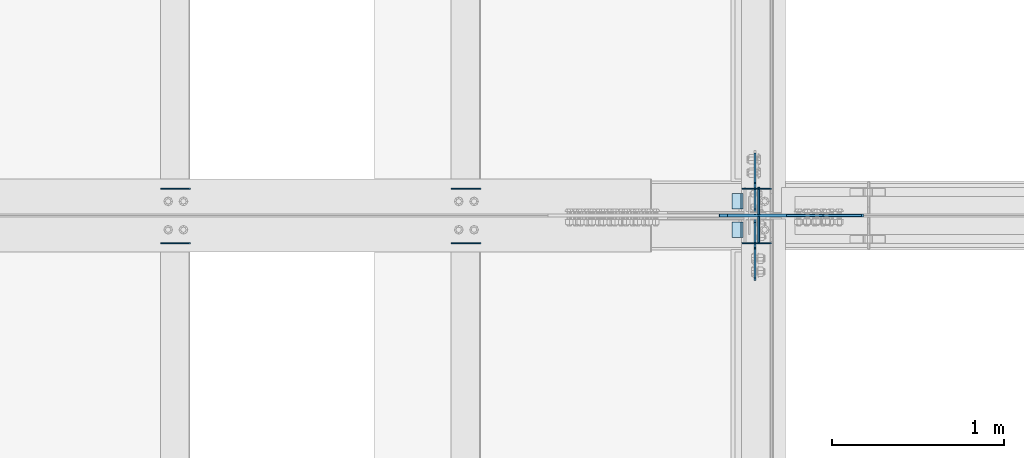
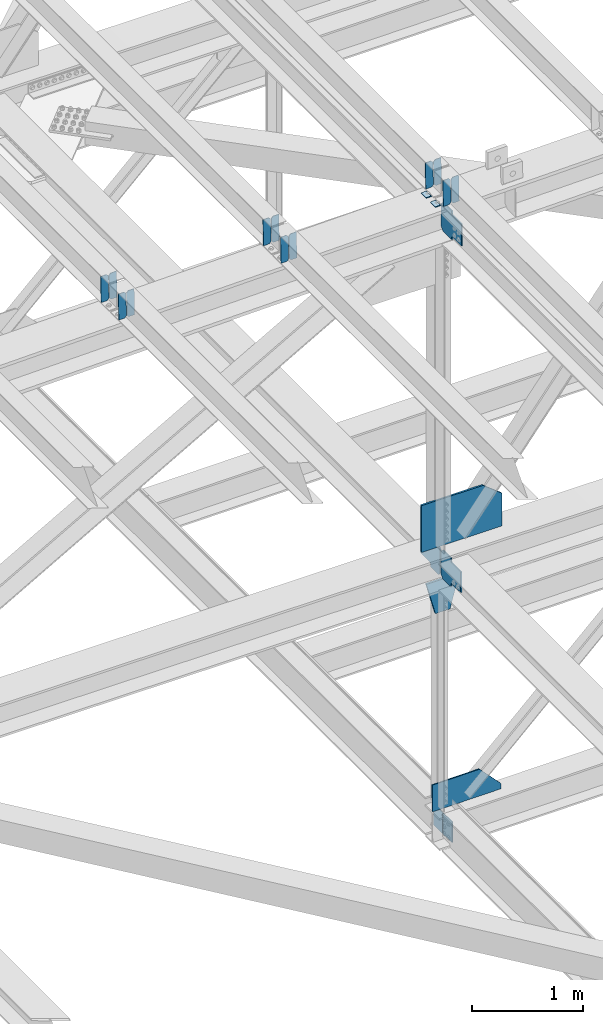
# One storey, part 3315 of 3843: 22 plates, 9 elements without a shape of their own.
"""IFC2X3 building model written with IfcOpenShell, lengths in millimetres."""

import ifcopenshell
import ifcopenshell.guid

model = None  # the IFC model being written
_history = None  # IfcOwnerHistory: only IFC2X3 demands one
_inside = {}  # id of a spatial element -> (the spatial element, [elements in it])
_under = {}  # id of a project, library or spatial element -> (it, [spatial elements below it])
_declared = {}  # id of a project -> (the project, [libraries it declares])
_typed = {}  # id of a type object -> (the type object, [elements of that type])
_made_of = {}  # id of a material, layer set ... -> (it, [elements and type objects made of it])


def new_model(schema):
    """Start an empty IFC model of exactly this schema.

    Asked for "IFC4X3", IfcOpenShell would pick the latest addendum, in which some entities
    have other attributes; the version numbers below select the first issue.
    IFC2X3 requires an IfcOwnerHistory on every rooted entity: one is made here for all.
    """
    global model, _history
    if schema == "IFC4X3":
        model = ifcopenshell.file(schema_version=(4, 3, 0, 0))
    else:
        model = ifcopenshell.file(schema=schema)
    _inside.clear()
    _under.clear()
    _declared.clear()
    _typed.clear()
    _made_of.clear()
    _history = None
    if model.schema == "IFC2X3":
        org = make("IfcOrganization", Name="unknown")
        user = make(
            "IfcPersonAndOrganization",
            ThePerson=make("IfcPerson", FamilyName="unknown"),
            TheOrganization=org,
        )
        app = make(
            "IfcApplication",
            ApplicationDeveloper=org,
            Version="unknown",
            ApplicationFullName="unknown",
            ApplicationIdentifier="unknown",
        )
        _history = make(
            "IfcOwnerHistory",
            OwningUser=user,
            OwningApplication=app,
            ChangeAction="ADDED",
            CreationDate=0,
        )
    return model


def make(cls, **values):
    """One entity of the class cls with the attributes given. An attribute that is None is left unset."""
    return model.create_entity(
        cls, **{name: value for name, value in values.items() if value is not None}
    )


def rooted(cls, **values):
    """An entity with a GlobalId (a new one), such as an element, a storey or a relation."""
    return make(cls, GlobalId=ifcopenshell.guid.new(), OwnerHistory=_history, **values)


def si_unit(unit_type, name, prefix=None):
    """IfcSIUnit, for example si_unit("LENGTHUNIT", "METRE", prefix="MILLI")."""
    return make("IfcSIUnit", UnitType=unit_type, Prefix=prefix, Name=name)


def assignment(units):
    """IfcUnitAssignment: the units of a project."""
    return None if units is None else make("IfcUnitAssignment", Units=units)


def point(xyz):
    """IfcCartesianPoint."""
    return None if xyz is None else make("IfcCartesianPoint", Coordinates=xyz)


def direction(xyz):
    """IfcDirection."""
    return None if xyz is None else make("IfcDirection", DirectionRatios=xyz)


def frame(location, z_axis=None, x_axis=None):
    """IfcAxis2Placement3D, a coordinate frame: its origin and axes. An axis left out is left unset."""
    return make(
        "IfcAxis2Placement3D",
        Location=point(location),
        Axis=direction(z_axis),
        RefDirection=direction(x_axis),
    )


def origin_with_axes():
    """The frame at (0, 0, 0) with the z axis (0, 0, 1) and the x axis (1, 0, 0) written out."""
    return frame((0.0, 0.0, 0.0), z_axis=(0.0, 0.0, 1.0), x_axis=(1.0, 0.0, 0.0))


def place(relative_to, where):
    """IfcLocalPlacement: puts the frame where relative to a parent placement (None: the world)."""
    return make(
        "IfcLocalPlacement", PlacementRelTo=relative_to, RelativePlacement=where
    )


def context(
    kind, dimensions, precision=None, world=None, true_north=None, identifier=None
):
    """IfcGeometricRepresentationContext, for example the 3D "Model" context."""
    return make(
        "IfcGeometricRepresentationContext",
        ContextIdentifier=identifier,
        ContextType=kind,
        CoordinateSpaceDimension=dimensions,
        Precision=precision,
        WorldCoordinateSystem=world,
        TrueNorth=true_north,
    )


def subcontext(parent, identifier, kind, view, scale=None):
    """IfcGeometricRepresentationSubContext, for example "Body" below "Model"."""
    return make(
        "IfcGeometricRepresentationSubContext",
        ContextIdentifier=identifier,
        ContextType=kind,
        ParentContext=parent,
        TargetScale=scale,
        TargetView=view,
    )


def project(units=None, contexts=None):
    """IfcProject with its units and contexts."""
    return rooted(
        "IfcProject",
        Name="project",
        RepresentationContexts=contexts,
        UnitsInContext=assignment(units),
    )


def spatial(cls, under=None, at=None, **own):
    """A site, building, storey or space (cls), placed at a placement, below another one or the project."""
    s = rooted(cls, ObjectPlacement=at, **own)
    if under is not None:
        _under.setdefault(under.id(), (under, []))[1].append(s)
    return s


def faces_of(points, faces, orient=None, outer=None):
    """IfcFace entities. A face is a list of loops; a loop is a list of indices into points, from 0.

    orient and outer hold one flag for each loop. By default every Orientation is true, the
    first loop of a face is its IfcFaceOuterBound and the others are IfcFaceBound.
    """
    made = []
    for i, loops in enumerate(faces):
        bounds = []
        for j, loop in enumerate(loops):
            is_outer = j == 0 if outer is None else outer[i][j]
            bounds.append(
                make(
                    "IfcFaceOuterBound" if is_outer else "IfcFaceBound",
                    Bound=make("IfcPolyLoop", Polygon=[points[k] for k in loop]),
                    Orientation=True if orient is None else orient[i][j],
                )
            )
        made.append(make("IfcFace", Bounds=bounds))
    return made


def faceted_brep(points, faces, orient=None, outer=None, voids=None):
    """IfcFacetedBrep: a solid bounded by flat faces; with voids (closed shells), ...WithVoids."""
    shared = [point(p) for p in points]
    hull = make("IfcClosedShell", CfsFaces=faces_of(shared, faces, orient, outer))
    if voids is None:
        return make("IfcFacetedBrep", Outer=hull)
    return make(
        "IfcFacetedBrepWithVoids",
        Outer=hull,
        Voids=[
            make(cls, CfsFaces=faces_of(shared, fs, o, b)) for cls, fs, o, b in voids
        ],
    )


def shape(context_of_items, identifier, shape_type, items):
    """IfcShapeRepresentation: the items that make up one representation, for example the "Body"."""
    return make(
        "IfcShapeRepresentation",
        ContextOfItems=context_of_items,
        RepresentationIdentifier=identifier,
        RepresentationType=shape_type,
        Items=items,
    )


def material(Name=None, Category=None):
    """IfcMaterial."""
    return make("IfcMaterial", Name=Name, Category=Category)


def made_of(thing, what):
    """Note that an element or type object is made of a material, layer set ...; save() writes the relation."""
    if what is not None:
        _made_of.setdefault(what.id(), (what, []))[1].append(thing)
    return thing


def type_object(cls, material=None, **own):
    """A type object (cls), such as IfcWallType, which elements share."""
    return made_of(rooted(cls, **own), material)


def element(
    cls,
    number,
    at=None,
    inside=None,
    cuts=None,
    type_object=None,
    material=None,
    context=None,
    identifier="Body",
    shape_type=None,
    held_by="IfcProductDefinitionShape",
    body=None,
    shapes=None,
    **own,
):
    """One element of the class cls, such as IfcWall. Its Tag is "e" and its number.

    at: its placement. inside: the storey or other place that contains it. cuts: it is an
    opening in that element (IfcRelVoidsElement). A single representation is given by context,
    identifier, shape_type and body (its items); several are given by shapes. held_by: the class
    of the entity that holds the representations. save() writes the other relations.
    """
    e = rooted(cls, Tag="e%d" % number, ObjectPlacement=at, **own)
    if body is not None:
        shapes = [shape(context, identifier, shape_type, body)]
    if shapes is not None:
        e.Representation = make(held_by, Representations=shapes)
    if inside is not None:
        _inside.setdefault(inside.id(), (inside, []))[1].append(e)
    if cuts is not None:
        rooted(
            "IfcRelVoidsElement", RelatingBuildingElement=cuts, RelatedOpeningElement=e
        )
    if type_object is not None:
        _typed.setdefault(type_object.id(), (type_object, []))[1].append(e)
    return made_of(e, material)


def aggregate(whole, parts):
    """IfcRelAggregates: a whole, such as a stair, and the parts it consists of."""
    return rooted("IfcRelAggregates", RelatingObject=whole, RelatedObjects=parts)


def save(model, path):
    """Write the relations noted so far, then the file.

    IfcRelAggregates (storeys below a building ...), IfcRelContainedInSpatialStructure (elements
    in a storey), IfcRelDefinesByType, IfcRelAssociatesMaterial and IfcRelDeclares: one each for
    every whole, place, type object, material and project.
    """
    for whole, parts in _under.values():
        aggregate(whole, parts)
    for where, things in _inside.values():
        rooted(
            "IfcRelContainedInSpatialStructure",
            RelatedElements=things,
            RelatingStructure=where,
        )
    for kind, things in _typed.values():
        rooted("IfcRelDefinesByType", RelatedObjects=things, RelatingType=kind)
    for what, things in _made_of.values():
        rooted("IfcRelAssociatesMaterial", RelatedObjects=things, RelatingMaterial=what)
    for by, libraries in _declared.values():
        rooted("IfcRelDeclares", RelatingContext=by, RelatedDefinitions=libraries)
    model.write(path)


model = new_model("IFC2X3")

# Units and contexts
model_context = context("Model", 3, precision=1e-05, world=origin_with_axes())
body_context = subcontext(model_context, "Body", "Model", "MODEL_VIEW")
ifc_project = project(units=[si_unit("LENGTHUNIT", "METRE", prefix="MILLI"), si_unit("AREAUNIT", "SQUARE_METRE"), si_unit("VOLUMEUNIT", "CUBIC_METRE"), si_unit("MASSUNIT", "GRAM", prefix="KILO"), si_unit("TIMEUNIT", "SECOND"), si_unit("PLANEANGLEUNIT", "RADIAN"), si_unit("SOLIDANGLEUNIT", "STERADIAN"), si_unit("THERMODYNAMICTEMPERATUREUNIT", "DEGREE_CELSIUS"), si_unit("LUMINOUSINTENSITYUNIT", "LUMEN")], contexts=[model_context])

# Site, building, storey
site_placement = place(None, origin_with_axes())
site = spatial("IfcSite", under=ifc_project, at=site_placement, CompositionType="ELEMENT")
building_placement = place(site_placement, origin_with_axes())
building = spatial("IfcBuilding", under=site, at=building_placement, Name="Undefined", CompositionType="ELEMENT")
storey_placement = place(building_placement, origin_with_axes())
storey = spatial("IfcBuildingStorey", under=building, at=storey_placement, Name="Undefined", CompositionType="ELEMENT", Elevation=0.0)

# Assembly, plates
assembly_1_placement = place(storey_placement, origin_with_axes())
assembly_1 = element("IfcElementAssembly", 1, at=assembly_1_placement, inside=storey, Name="BEAM", AssemblyPlace="NOTDEFINED", PredefinedType="RIGID_FRAME")
ifc_material = material(Name="STEEL/A572-50")
plate_type_1 = type_object("IfcPlateType", PredefinedType="NOTDEFINED")
plate_1_placement = place(assembly_1_placement, frame((77095.0964786595, 50714.4467026229, 46378.0230430757), z_axis=(-0.0211520975154853, -0.000575795999735418, 0.999776103550021), x_axis=(-0.999776269355722, 1.23390000256453e-05, -0.0211520940075457)))
plate_1 = element("IfcPlate", 2, at=plate_1_placement, type_object=plate_type_1, material=ifc_material, Name="PLATE", context=body_context, shape_type="Brep", body=[
    faceted_brep([(0.0, -3.17499999999927, 0.0), (6.83940015733242e-10, -3.17499999996653, 288.924999998613), (6.54836185276508e-10, 3.17500000001746, 288.924999998591), (0.0, 3.17499999999927, 0.0), (60.3250007643655, -3.17500000017753, 288.924999998606), (60.3250007643219, 3.17499999979918, 288.924999998584), (79.3750000013097, -3.17500000025029, 269.875000761494), (79.375000001266, 3.17499999972642, 269.875000761487), (79.375000000713, -3.17500000026484, 19.0499992370605), (79.3750000006985, 3.17499999971187, 19.0499992370533), (60.325000763667, -3.17500000020664, -1.45519152283669e-11), (60.3250007636234, 3.17499999977736, -3.63797880709171e-11)], [[[0, 1, 2, 3]], [[1, 4, 5, 2]], [[4, 6, 7, 5]], [[6, 8, 9, 7]], [[8, 10, 11, 9]], [[10, 0, 3, 11]], [[5, 7, 9, 11, 3, 2]], [[10, 8, 6, 4, 1, 0]]]),
])
plate_2_placement = place(assembly_1_placement, frame((77009.3906579693, 50714.4477469266, 46376.2097797763), z_axis=(-0.0211520975154853, -0.000575795999735418, 0.999776103550021), x_axis=(-0.999776269355722, 1.23390000256453e-05, -0.0211520940075457)))
plate_2 = element("IfcPlate", 3, at=plate_2_placement, type_object=plate_type_1, material=ifc_material, Name="PLATE", context=body_context, shape_type="Brep", body=[
    faceted_brep([(4.36557456851006e-11, -3.17499999998836, 19.0499992370969), (6.11180439591408e-10, -3.17499999996653, 269.875000761516), (5.96628524363041e-10, 3.17500000001746, 269.875000761502), (1.45519152283669e-11, 3.17499999998836, 19.0499992370824), (19.0499992376572, -3.17500000003201, 288.924999998606), (19.0499992376281, 3.1749999999447, 288.924999998584), (79.3750000013242, -3.17500000025029, 288.924999998591), (79.3750000013097, 3.1749999997337, 288.92499999857), (79.3750000006548, -3.17500000026484, -2.18278728425503e-11), (79.3750000006403, 3.17499999969732, -2.91038304567337e-11), (19.0499992370023, -3.17500000005384, 0.0), (19.0499992369587, 3.17499999992287, -1.45519152283669e-11)], [[[0, 1, 2, 3]], [[1, 4, 5, 2]], [[4, 6, 7, 5]], [[6, 8, 9, 7]], [[8, 10, 11, 9]], [[10, 0, 3, 11]], [[5, 7, 9, 11, 3, 2]], [[10, 8, 6, 4, 1, 0]]]),
])

assembly_2_placement = place(storey_placement, origin_with_axes())
assembly_2 = element("IfcElementAssembly", 4, at=assembly_2_placement, inside=storey, Name="BEAM", AssemblyPlace="NOTDEFINED", PredefinedType="RIGID_FRAME")
plate_3_placement = place(assembly_2_placement, frame((77095.096478342, 50397.4235296418, 46377.5830662647), z_axis=(-0.0211520979065535, -0.00217161999968084, 0.999773910852213), x_axis=(-0.999776269348977, 4.5491000049241e-05, -0.0211520490073722)))
plate_3 = element("IfcPlate", 5, at=plate_3_placement, type_object=plate_type_1, material=ifc_material, Name="PLATE", context=body_context, shape_type="Brep", body=[
    faceted_brep([(0.0, -3.17499999999927, 0.0), (6.83940015733242e-10, -3.17499999996653, 288.924999998613), (6.54836185276508e-10, 3.17500000001746, 288.924999998591), (0.0, 3.17499999999927, 0.0), (60.3250007643655, -3.17500000017753, 288.924999998606), (60.3250007643219, 3.17499999979918, 288.924999998584), (79.3750000013097, -3.17500000025029, 269.875000761494), (79.375000001266, 3.17499999972642, 269.875000761487), (79.375000000713, -3.17500000026484, 19.0499992370605), (79.3750000006985, 3.17499999971187, 19.0499992370533), (60.325000763667, -3.17500000020664, -1.45519152283669e-11), (60.3250007636234, 3.17499999977736, -3.63797880709171e-11)], [[[0, 1, 2, 3]], [[1, 4, 5, 2]], [[4, 6, 7, 5]], [[6, 8, 9, 7]], [[8, 10, 11, 9]], [[10, 0, 3, 11]], [[5, 7, 9, 11, 3, 2]], [[10, 8, 6, 4, 1, 0]]]),
])
plate_4_placement = place(assembly_2_placement, frame((77009.3906576517, 50397.4274682428, 46375.7698069418), z_axis=(-0.0211520979065535, -0.00217161999968084, 0.999773910852213), x_axis=(-0.999776269348977, 4.5491000049241e-05, -0.0211520490073722)))
plate_4 = element("IfcPlate", 6, at=plate_4_placement, type_object=plate_type_1, material=ifc_material, Name="PLATE", context=body_context, shape_type="Brep", body=[
    faceted_brep([(4.36557456851006e-11, -3.17499999998836, 19.0499992370969), (6.11180439591408e-10, -3.17499999996653, 269.875000761516), (5.96628524363041e-10, 3.17500000001746, 269.875000761502), (1.45519152283669e-11, 3.17499999998836, 19.0499992370824), (19.0499992376572, -3.17500000003201, 288.924999998606), (19.0499992376281, 3.1749999999447, 288.924999998584), (79.3750000013242, -3.17500000025029, 288.924999998591), (79.3750000013097, 3.1749999997337, 288.92499999857), (79.3750000006548, -3.17500000026484, -2.18278728425503e-11), (79.3750000006403, 3.17499999969732, -2.91038304567337e-11), (19.0499992370023, -3.17500000005384, 0.0), (19.0499992369587, 3.17499999992287, -1.45519152283669e-11)], [[[0, 1, 2, 3]], [[1, 4, 5, 2]], [[4, 6, 7, 5]], [[6, 8, 9, 7]], [[8, 10, 11, 9]], [[10, 0, 3, 11]], [[5, 7, 9, 11, 3, 2]], [[10, 8, 6, 4, 1, 0]]]),
])

assembly_3_placement = place(storey_placement, origin_with_axes())
assembly_3 = element("IfcElementAssembly", 7, at=assembly_3_placement, inside=storey, Name="BEAM", AssemblyPlace="NOTDEFINED", PredefinedType="RIGID_FRAME")
plate_5_placement = place(assembly_3_placement, frame((75405.9964783706, 50714.4395480558, 46344.7456504675), z_axis=(-0.0211520982287039, -0.000551804000038829, 0.99977611706465), x_axis=(-0.999776269355722, 1.23390000256453e-05, -0.0211520940075457)))
plate_5 = element("IfcPlate", 8, at=plate_5_placement, type_object=plate_type_1, material=ifc_material, Name="PLATE", context=body_context, shape_type="Brep", body=[
    faceted_brep([(0.0, -3.17499999999927, 0.0), (6.83940015733242e-10, -3.17499999996653, 288.924999998613), (6.54836185276508e-10, 3.17500000001746, 288.924999998591), (0.0, 3.17499999999927, 0.0), (60.3250007643655, -3.17500000017753, 288.924999998606), (60.3250007643219, 3.17499999979918, 288.924999998584), (79.3750000013097, -3.17500000025029, 269.875000761494), (79.375000001266, 3.17499999972642, 269.875000761487), (79.375000000713, -3.17500000026484, 19.0499992370605), (79.3750000006985, 3.17499999971187, 19.0499992370533), (60.325000763667, -3.17500000020664, -1.45519152283669e-11), (60.3250007636234, 3.17499999977736, -3.63797880709171e-11)], [[[0, 1, 2, 3]], [[1, 4, 5, 2]], [[4, 6, 7, 5]], [[6, 8, 9, 7]], [[8, 10, 11, 9]], [[10, 0, 3, 11]], [[5, 7, 9, 11, 3, 2]], [[10, 8, 6, 4, 1, 0]]]),
])
plate_6_placement = place(assembly_3_placement, frame((75320.2906576794, 50714.440548845, 46342.9323871429), z_axis=(-0.0211520982287039, -0.000551804000038829, 0.99977611706465), x_axis=(-0.999776269355722, 1.23390000256453e-05, -0.0211520940075457)))
plate_6 = element("IfcPlate", 9, at=plate_6_placement, type_object=plate_type_1, material=ifc_material, Name="PLATE", context=body_context, shape_type="Brep", body=[
    faceted_brep([(4.36557456851006e-11, -3.17499999998836, 19.0499992370969), (6.11180439591408e-10, -3.17499999996653, 269.875000761516), (5.96628524363041e-10, 3.17500000001746, 269.875000761502), (1.45519152283669e-11, 3.17499999998836, 19.0499992370824), (19.0499992376572, -3.17500000003201, 288.924999998606), (19.0499992376281, 3.1749999999447, 288.924999998584), (79.3750000013242, -3.17500000025029, 288.924999998591), (79.3750000013097, 3.1749999997337, 288.92499999857), (79.3750000006548, -3.17500000026484, -2.18278728425503e-11), (79.3750000006403, 3.17499999969732, -2.91038304567337e-11), (19.0499992370023, -3.17500000005384, 0.0), (19.0499992369587, 3.17499999992287, -1.45519152283669e-11)], [[[0, 1, 2, 3]], [[1, 4, 5, 2]], [[4, 6, 7, 5]], [[6, 8, 9, 7]], [[8, 10, 11, 9]], [[10, 0, 3, 11]], [[5, 7, 9, 11, 3, 2]], [[10, 8, 6, 4, 1, 0]]]),
])
aggregate(assembly_3, [plate_5, plate_6])

assembly_4_placement = place(storey_placement, origin_with_axes())
assembly_4 = element("IfcElementAssembly", 10, at=assembly_4_placement, inside=storey, Name="BEAM", AssemblyPlace="NOTDEFINED", PredefinedType="RIGID_FRAME")
plate_7_placement = place(assembly_4_placement, frame((75405.99647829, 50397.4213613454, 46344.3105730398), z_axis=(-0.0211520975879684, -0.0021646719998389, 0.999773925926638), x_axis=(-0.999776269348977, 4.5491000049241e-05, -0.0211520490073722)))
plate_7 = element("IfcPlate", 11, at=plate_7_placement, type_object=plate_type_1, material=ifc_material, Name="PLATE", context=body_context, shape_type="Brep", body=[
    faceted_brep([(0.0, -3.17499999999927, 0.0), (6.83940015733242e-10, -3.17499999996653, 288.924999998613), (6.54836185276508e-10, 3.17500000001746, 288.924999998591), (0.0, 3.17499999999927, 0.0), (60.3250007643655, -3.17500000017753, 288.924999998606), (60.3250007643219, 3.17499999979918, 288.924999998584), (79.3750000013097, -3.17500000025029, 269.875000761494), (79.375000001266, 3.17499999972642, 269.875000761487), (79.375000000713, -3.17500000026484, 19.0499992370605), (79.3750000006985, 3.17499999971187, 19.0499992370533), (60.325000763667, -3.17500000020664, -1.45519152283669e-11), (60.3250007636234, 3.17499999977736, -3.63797880709171e-11)], [[[0, 1, 2, 3]], [[1, 4, 5, 2]], [[4, 6, 7, 5]], [[6, 8, 9, 7]], [[8, 10, 11, 9]], [[10, 0, 3, 11]], [[5, 7, 9, 11, 3, 2]], [[10, 8, 6, 4, 1, 0]]]),
])
plate_8_placement = place(assembly_4_placement, frame((75320.2906575989, 50397.4252868452, 46342.4973136883), z_axis=(-0.0211520975879684, -0.0021646719998389, 0.999773925926638), x_axis=(-0.999776269348977, 4.5491000049241e-05, -0.0211520490073722)))
plate_8 = element("IfcPlate", 12, at=plate_8_placement, type_object=plate_type_1, material=ifc_material, Name="PLATE", context=body_context, shape_type="Brep", body=[
    faceted_brep([(4.36557456851006e-11, -3.17499999998836, 19.0499992370969), (6.11180439591408e-10, -3.17499999996653, 269.875000761516), (5.96628524363041e-10, 3.17500000001746, 269.875000761502), (1.45519152283669e-11, 3.17499999998836, 19.0499992370824), (19.0499992376572, -3.17500000003201, 288.924999998606), (19.0499992376281, 3.1749999999447, 288.924999998584), (79.3750000013242, -3.17500000025029, 288.924999998591), (79.3750000013097, 3.1749999997337, 288.92499999857), (79.3750000006548, -3.17500000026484, -2.18278728425503e-11), (79.3750000006403, 3.17499999969732, -2.91038304567337e-11), (19.0499992370023, -3.17500000005384, 0.0), (19.0499992369587, 3.17499999992287, -1.45519152283669e-11)], [[[0, 1, 2, 3]], [[1, 4, 5, 2]], [[4, 6, 7, 5]], [[6, 8, 9, 7]], [[8, 10, 11, 9]], [[10, 0, 3, 11]], [[5, 7, 9, 11, 3, 2]], [[10, 8, 6, 4, 1, 0]]]),
])
aggregate(assembly_4, [plate_7, plate_8])

assembly_5_placement = place(storey_placement, origin_with_axes())
assembly_5 = element("IfcElementAssembly", 13, at=assembly_5_placement, inside=storey, Name="BEAM", AssemblyPlace="NOTDEFINED", PredefinedType="RIGID_FRAME")
plate_9_placement = place(assembly_5_placement, frame((73716.8964782891, 50714.4323955122, 46310.9171851045), z_axis=(-0.0211520979550987, -0.000527811000014481, 0.99977613002494), x_axis=(-0.999776269357268, 1.0337000006824e-05, -0.0211520950075907)))
plate_9 = element("IfcPlate", 14, at=plate_9_placement, type_object=plate_type_1, material=ifc_material, Name="PLATE", context=body_context, shape_type="Brep", body=[
    faceted_brep([(0.0, -3.17499999999927, 0.0), (6.83940015733242e-10, -3.17499999996653, 288.924999998613), (6.54836185276508e-10, 3.17500000001746, 288.924999998591), (0.0, 3.17499999999927, 0.0), (60.3250007643655, -3.17500000017753, 288.924999998606), (60.3250007643219, 3.17499999979918, 288.924999998584), (79.3750000013097, -3.17500000025029, 269.875000761494), (79.375000001266, 3.17499999972642, 269.875000761487), (79.375000000713, -3.17500000026484, 19.0499992370605), (79.3750000006985, 3.17499999971187, 19.0499992370533), (60.325000763667, -3.17500000020664, -1.45519152283669e-11), (60.3250007636234, 3.17499999977736, -3.63797880709171e-11)], [[[0, 1, 2, 3]], [[1, 4, 5, 2]], [[4, 6, 7, 5]], [[6, 8, 9, 7]], [[8, 10, 11, 9]], [[10, 0, 3, 11]], [[5, 7, 9, 11, 3, 2]], [[10, 8, 6, 4, 1, 0]]]),
])
plate_10_placement = place(assembly_5_placement, frame((73631.190657598, 50714.4333527863, 46309.1039217558), z_axis=(-0.0211520979550987, -0.000527811000014481, 0.99977613002494), x_axis=(-0.999776269357268, 1.0337000006824e-05, -0.0211520950075907)))
plate_10 = element("IfcPlate", 15, at=plate_10_placement, type_object=plate_type_1, material=ifc_material, Name="PLATE", context=body_context, shape_type="Brep", body=[
    faceted_brep([(4.36557456851006e-11, -3.17499999998836, 19.0499992370969), (6.11180439591408e-10, -3.17499999996653, 269.875000761516), (5.96628524363041e-10, 3.17500000001746, 269.875000761502), (1.45519152283669e-11, 3.17499999998836, 19.0499992370824), (19.0499992376572, -3.17500000003201, 288.924999998606), (19.0499992376281, 3.1749999999447, 288.924999998584), (79.3750000013242, -3.17500000025029, 288.924999998591), (79.3750000013097, 3.1749999997337, 288.92499999857), (79.3750000006548, -3.17500000026484, -2.18278728425503e-11), (79.3750000006403, 3.17499999969732, -2.91038304567337e-11), (19.0499992370023, -3.17500000005384, 0.0), (19.0499992369587, 3.17499999992287, -1.45519152283669e-11)], [[[0, 1, 2, 3]], [[1, 4, 5, 2]], [[4, 6, 7, 5]], [[6, 8, 9, 7]], [[8, 10, 11, 9]], [[10, 0, 3, 11]], [[5, 7, 9, 11, 3, 2]], [[10, 8, 6, 4, 1, 0]]]),
])
aggregate(assembly_5, [plate_9, plate_10])

assembly_6_placement = place(storey_placement, origin_with_axes())
assembly_6 = element("IfcElementAssembly", 16, at=assembly_6_placement, inside=storey, Name="BEAM", AssemblyPlace="NOTDEFINED", PredefinedType="RIGID_FRAME")
plate_11_placement = place(assembly_6_placement, frame((73716.8964782891, 50397.4170119716, 46310.4881845828), z_axis=(-0.0211520979252964, -0.00215017300044565, 0.999773957207041), x_axis=(-0.999776269348977, 4.5491000049241e-05, -0.0211520490073722)))
plate_11 = element("IfcPlate", 17, at=plate_11_placement, type_object=plate_type_1, material=ifc_material, Name="PLATE", context=body_context, shape_type="Brep", body=[
    faceted_brep([(0.0, -3.17499999999927, 0.0), (6.83940015733242e-10, -3.17499999996653, 288.924999998613), (6.54836185276508e-10, 3.17500000001746, 288.924999998591), (0.0, 3.17499999999927, 0.0), (60.3250007643655, -3.17500000017753, 288.924999998606), (60.3250007643219, 3.17499999979918, 288.924999998584), (79.3750000013097, -3.17500000025029, 269.875000761494), (79.375000001266, 3.17499999972642, 269.875000761487), (79.375000000713, -3.17500000026484, 19.0499992370605), (79.3750000006985, 3.17499999971187, 19.0499992370533), (60.325000763667, -3.17500000020664, -1.45519152283669e-11), (60.3250007636234, 3.17499999977736, -3.63797880709171e-11)], [[[0, 1, 2, 3]], [[1, 4, 5, 2]], [[4, 6, 7, 5]], [[6, 8, 9, 7]], [[8, 10, 11, 9]], [[10, 0, 3, 11]], [[5, 7, 9, 11, 3, 2]], [[10, 8, 6, 4, 1, 0]]]),
])
plate_12_placement = place(assembly_6_placement, frame((73631.190657598, 50397.4209110838, 46308.6749251742), z_axis=(-0.0211520979252964, -0.00215017300044565, 0.999773957207041), x_axis=(-0.999776269348977, 4.5491000049241e-05, -0.0211520490073722)))
plate_12 = element("IfcPlate", 18, at=plate_12_placement, type_object=plate_type_1, material=ifc_material, Name="PLATE", context=body_context, shape_type="Brep", body=[
    faceted_brep([(4.36557456851006e-11, -3.17499999998836, 19.0499992370969), (6.11180439591408e-10, -3.17499999996653, 269.875000761516), (5.96628524363041e-10, 3.17500000001746, 269.875000761502), (1.45519152283669e-11, 3.17499999998836, 19.0499992370824), (19.0499992376572, -3.17500000003201, 288.924999998606), (19.0499992376281, 3.1749999999447, 288.924999998584), (79.3750000013242, -3.17500000025029, 288.924999998591), (79.3750000013097, 3.1749999997337, 288.92499999857), (79.3750000006548, -3.17500000026484, -2.18278728425503e-11), (79.3750000006403, 3.17499999969732, -2.91038304567337e-11), (19.0499992370023, -3.17500000005384, 0.0), (19.0499992369587, 3.17499999992287, -1.45519152283669e-11)], [[[0, 1, 2, 3]], [[1, 4, 5, 2]], [[4, 6, 7, 5]], [[6, 8, 9, 7]], [[8, 10, 11, 9]], [[10, 0, 3, 11]], [[5, 7, 9, 11, 3, 2]], [[10, 8, 6, 4, 1, 0]]]),
])
aggregate(assembly_6, [plate_11, plate_12])

# Plate
plate_type_2 = type_object("IfcPlateType", PredefinedType="NOTDEFINED")
plate_13_placement = place(assembly_1_placement, frame((76930.1677317969, 50685.7, 46368.0925779329), z_axis=(0.0, -1.0, 0.0), x_axis=(-0.999776270257024, 0.0, -0.0211520550054595)))
plate_13 = element("IfcPlate", 19, at=plate_13_placement, type_object=plate_type_2, material=ifc_material, Name="PLATE", context=body_context, shape_type="Brep", body=[
    faceted_brep([(9.52499999982683, -4.7625000001135, 88.8999999999942), (0.0, 4.76249999999709, 88.9000015258789), (0.0, 4.76249999999709, 0.0), (9.52499999981956, -4.76249999999709, 0.0), (63.4999984608512, -4.76249999988795, 88.8999999999796), (63.4999984608367, -4.76249999988795, -1.45519152283669e-11), (63.4999984608221, 4.76250000013533, -1.45519152283669e-11), (63.4999984608367, 4.76250000013533, 88.8999999999796)], [[[0, 1, 2, 3]], [[4, 5, 6, 7]], [[5, 4, 0, 3]], [[6, 5, 3, 2]], [[7, 6, 2, 1]], [[4, 7, 1, 0]]]),
])

aggregate(assembly_1, [plate_1, plate_2, plate_13])

plate_14_placement = place(assembly_2_placement, frame((76930.1677317969, 50520.6000015258, 46368.0925779329), z_axis=(0.0, -1.0, 0.0), x_axis=(-0.999776270257024, 0.0, -0.0211520550054595)))
plate_14 = element("IfcPlate", 20, at=plate_14_placement, type_object=plate_type_2, material=ifc_material, Name="PLATE", context=body_context, shape_type="Brep", body=[
    faceted_brep([(9.52499999982683, -4.7625000001135, 88.8999999999942), (0.0, 4.76249999999709, 88.9000015258789), (0.0, 4.76249999999709, 0.0), (9.52499999981956, -4.76249999999709, 0.0), (63.4999984608512, -4.76249999988795, 88.8999999999796), (63.4999984608367, -4.76249999988795, -1.45519152283669e-11), (63.4999984608221, 4.76250000013533, -1.45519152283669e-11), (63.4999984608367, 4.76250000013533, 88.8999999999796)], [[[0, 1, 2, 3]], [[4, 5, 6, 7]], [[5, 4, 0, 3]], [[6, 5, 3, 2]], [[7, 6, 2, 1]], [[4, 7, 1, 0]]]),
])

aggregate(assembly_2, [plate_3, plate_4, plate_14])

# Assembly, plates
assembly_7_placement = place(storey_placement, origin_with_axes())
assembly_7 = element("IfcElementAssembly", 21, at=assembly_7_placement, inside=storey, Name="BEAM", AssemblyPlace="NOTDEFINED", PredefinedType="RIGID_FRAME")
plate_type_3 = type_object("IfcPlateType", PredefinedType="NOTDEFINED")
plate_15_placement = place(assembly_7_placement, frame((77001.6874998598, 50565.8437469886, 42210.7702581127), z_axis=(0.0, 0.707106781186548, 0.707106781186548), x_axis=(5.70000238222118e-08, 0.707106781186546, -0.707106781186546)))
plate_15 = element("IfcPlate", 22, at=plate_15_placement, type_object=plate_type_3, material=ifc_material, Name="PLATE", context=body_context, shape_type="Brep", body=[
    faceted_brep([(0.0, -6.3499999046162, 0.0), (-179.591137731415, -6.35000000000582, 179.591137731419), (-179.591137731415, 6.35000000000582, 179.591137731419), (7.27595761418343e-12, 6.3499999046162, 0.0), (-179.591137731411, -6.35000000000582, 224.492418336551), (-179.591137731411, 6.35000000000582, 224.492418336551), (-75.7569263320693, -6.35000000000582, 328.326629735893), (-75.7569263320693, 6.35000000000582, 328.326629735893), (-53.4140304639586, -6.35000000000582, 305.983733867775), (-53.4140304639586, 6.35000000000582, 305.983733867775), (-49.2938539958122, -6.35000000000582, 303.230719967309), (-49.2938539958122, 6.35000000000582, 303.230719967309), (-44.4337744777804, -6.35000000000582, 302.263990044725), (-44.4337744777804, 6.35000000000582, 302.263990044725), (-39.5736949597485, -6.35000000000582, 303.230719967309), (-39.5736949597485, 6.35000000000582, 303.230719967309), (-35.4535184916022, -6.35000000000582, 305.983733867775), (-35.4535184916022, 6.35000000000582, 305.983733867775), (81.289811216604, -6.35000000000582, 422.727063575992), (81.289811216604, 6.35000000000582, 422.727063575992), (242.934421395075, -6.35000000000582, 261.082453397525), (242.934421395075, 6.35000000000582, 261.082453397525), (126.191091686869, -6.35000000000582, 144.339123689308), (126.191091686869, 6.35000000000582, 144.339123689308), (123.438077786399, -6.35000000000582, 140.218947221161), (123.438077786399, 6.35000000000582, 140.218947221161), (122.471347863811, -6.35000000000582, 135.358867703122), (122.471347863811, 6.35000000000582, 135.358867703122), (123.438077786399, -6.35000000000582, 130.498788185098), (123.438077786399, 6.35000000000582, 130.498788185098), (126.191091686869, -6.35000000000582, 126.378611716951), (126.191091686869, 6.35000000000582, 126.378611716951), (148.735492004496, -6.35000000000582, 103.834211399357), (148.735492004496, 6.35000000000582, 103.834211399357), (44.9012806051323, -6.35000000000582, -1.45519152283669e-11), (44.9012806051323, 6.35000000000582, -1.45519152283669e-11)], [[[0, 1, 2, 3]], [[1, 4, 5, 2]], [[4, 6, 7, 5]], [[6, 8, 9, 7]], [[8, 10, 11, 9]], [[10, 12, 13, 11]], [[12, 14, 15, 13]], [[14, 16, 17, 15]], [[16, 18, 19, 17]], [[18, 20, 21, 19]], [[20, 22, 23, 21]], [[22, 24, 25, 23]], [[24, 26, 27, 25]], [[26, 28, 29, 27]], [[28, 30, 31, 29]], [[30, 32, 33, 31]], [[32, 34, 35, 33]], [[34, 0, 3, 35]], [[5, 7, 9, 11, 13, 15, 17, 19, 21, 23, 25, 27, 29, 31, 33, 35, 3, 2]], [[34, 32, 30, 28, 26, 24, 22, 20, 18, 16, 14, 12, 10, 8, 6, 4, 1, 0]]]),
])
plate_16_placement = place(assembly_7_placement, frame((77001.6874999361, 50551.5562469932, 42210.7702581545), z_axis=(0.0, -0.707106781186682, 0.707106781186413), x_axis=(0.0, -0.707106781186548, -0.707106781186548)))
plate_16 = element("IfcPlate", 23, at=plate_16_placement, type_object=plate_type_3, material=ifc_material, Name="PLATE", context=body_context, shape_type="Brep", body=[
    faceted_brep([(0.0, -6.3499999046162, 0.0), (-179.591137731415, -6.35000000000582, 179.591137731419), (-179.591137731415, 6.35000000000582, 179.591137731419), (7.27595761418343e-12, 6.3499999046162, 0.0), (-179.591137731411, -6.35000000000582, 224.492418336551), (-179.591137731411, 6.35000000000582, 224.492418336551), (-75.7569263320693, -6.35000000000582, 328.326629735893), (-75.7569263320693, 6.35000000000582, 328.326629735893), (-52.9274417554843, -6.35000000000582, 305.497145165871), (-52.9274417554843, 6.35000000000582, 305.497145165871), (-48.8072652873379, -6.35000000000582, 302.744131265397), (-48.8072652873379, 6.35000000000582, 302.744131265397), (-43.9471857693134, -6.35000000000582, 301.777401342806), (-43.9471857693134, 6.35000000000582, 301.777401342806), (-39.0871062512742, -6.35000000000582, 302.744131265394), (-39.0871062512742, 6.35000000000582, 302.744131265394), (-34.9669297831279, -6.35000000000582, 305.497145165864), (-34.9669297831279, 6.35000000000582, 305.497145165864), (81.7763999218223, -6.35000000000582, 422.240474870789), (81.7763999218223, 6.35000000000582, 422.240474870789), (243.421010100268, -6.35000000000582, 260.595864692303), (243.421010100268, 6.35000000000582, 260.595864692303), (126.677680395325, -6.35000000000582, 143.852534987382), (126.677680395325, 6.35000000000582, 143.852534987382), (123.924666494844, -6.35000000000582, 139.732358519239), (123.924666494844, 6.35000000000582, 139.732358519239), (122.95793657226, -6.35000000000582, 134.8722790012), (122.95793657226, 6.35000000000582, 134.8722790012), (123.924666494844, -6.35000000000582, 130.012199483168), (123.924666494844, 6.35000000000582, 130.012199483168), (126.677680395318, -6.35000000000582, 125.892023015022), (126.677680395318, 6.35000000000582, 125.892023015022), (148.735492004496, -6.35000000000582, 103.834211399357), (148.735492004496, 6.35000000000582, 103.834211399357), (44.9012806051323, -6.35000000000582, -1.45519152283669e-11), (44.9012806051323, 6.35000000000582, -1.45519152283669e-11)], [[[0, 1, 2, 3]], [[1, 4, 5, 2]], [[4, 6, 7, 5]], [[6, 8, 9, 7]], [[8, 10, 11, 9]], [[10, 12, 13, 11]], [[12, 14, 15, 13]], [[14, 16, 17, 15]], [[16, 18, 19, 17]], [[18, 20, 21, 19]], [[20, 22, 23, 21]], [[22, 24, 25, 23]], [[24, 26, 27, 25]], [[26, 28, 29, 27]], [[28, 30, 31, 29]], [[30, 32, 33, 31]], [[32, 34, 35, 33]], [[34, 0, 3, 35]], [[5, 7, 9, 11, 13, 15, 17, 19, 21, 23, 25, 27, 29, 31, 33, 35, 3, 2]], [[34, 32, 30, 28, 26, 24, 22, 20, 18, 16, 14, 12, 10, 8, 6, 4, 1, 0]]]),
])

# Assembly, plate
assembly_8_placement = place(storey_placement, origin_with_axes())
assembly_8 = element("IfcElementAssembly", 24, at=assembly_8_placement, inside=storey, Name="BEAM", AssemblyPlace="NOTDEFINED", PredefinedType="RIGID_FRAME")
plate_17_placement = place(assembly_8_placement, frame((77000.8937495784, 50547.5875000823, 46041.0490581906), z_axis=(0.0, -0.707106781186682, 0.707106781186413), x_axis=(0.0, -0.707106781186548, -0.707106781186548)))
plate_17 = element("IfcPlate", 25, at=plate_17_placement, type_object=plate_type_3, material=ifc_material, Name="PLATE", context=body_context, shape_type="Brep", body=[
    faceted_brep([(0.0, -6.3499999046162, 0.0), (-179.473200360613, -6.35000000000582, 179.47320036059), (-179.473200360613, 6.35000000000582, 179.47320036059), (7.27595761418343e-12, 6.3499999046162, 0.0), (-179.473200360148, -6.35000000000582, 224.374480966202), (-179.473200360148, 6.35000000000582, 224.374480966202), (-68.3425308601163, -6.35000000000582, 335.505150466226), (-68.3425308601163, 6.35000000000582, 335.505150466226), (-50.2183380070637, -6.35000000000582, 317.380957724115), (-50.2183380070637, 6.35000000000582, 317.380957724115), (-46.0981615389173, -6.35000000000582, 314.627943823641), (-46.0981615389173, 6.35000000000582, 314.627943823641), (-41.2380820208928, -6.35000000000582, 313.661213901057), (-41.2380820208928, 6.35000000000582, 313.661213901057), (-36.3780025028536, -6.35000000000582, 314.627943823634), (-36.3780025028536, 6.35000000000582, 314.627943823634), (-32.2578260347073, -6.35000000000582, 317.380957724115), (-32.2578260347073, 6.35000000000582, 317.380957724115), (84.4855036152148, -6.35000000000582, 434.124287374037), (84.4855036152148, 6.35000000000582, 434.124287374037), (255.110369914735, -6.35000000000582, 263.499421074539), (255.110369914735, 6.35000000000582, 263.499421074539), (138.367040264799, -6.35000000000582, 146.756091424616), (138.367040264799, 6.35000000000582, 146.756091424616), (135.614026364317, -6.35000000000582, 142.635914956474), (135.614026364317, 6.35000000000582, 142.635914956474), (134.647296441733, -6.35000000000582, 137.775835438438), (134.647296441733, 6.35000000000582, 137.775835438438), (135.614026364317, -6.35000000000582, 132.915755920403), (135.614026364317, 6.35000000000582, 132.915755920403), (138.367040264799, -6.35000000000582, 128.79557945226), (138.367040264799, 6.35000000000582, 128.79557945226), (156.031950102829, -6.35000000000582, 111.130669497703), (156.031950102829, 6.35000000000582, 111.130669497703), (44.9012806051323, -6.35000000000582, -1.45519152283669e-11), (44.9012806051323, 6.35000000000582, -1.45519152283669e-11)], [[[0, 1, 2, 3]], [[1, 4, 5, 2]], [[4, 6, 7, 5]], [[6, 8, 9, 7]], [[8, 10, 11, 9]], [[10, 12, 13, 11]], [[12, 14, 15, 13]], [[14, 16, 17, 15]], [[16, 18, 19, 17]], [[18, 20, 21, 19]], [[20, 22, 23, 21]], [[22, 24, 25, 23]], [[24, 26, 27, 25]], [[26, 28, 29, 27]], [[28, 30, 31, 29]], [[30, 32, 33, 31]], [[32, 34, 35, 33]], [[34, 0, 3, 35]], [[5, 7, 9, 11, 13, 15, 17, 19, 21, 23, 25, 27, 29, 31, 33, 35, 3, 2]], [[34, 32, 30, 28, 26, 24, 22, 20, 18, 16, 14, 12, 10, 8, 6, 4, 1, 0]]]),
])
aggregate(assembly_8, [plate_17])

# Plate
plate_type_4 = type_object("IfcPlateType", PredefinedType="NOTDEFINED")
plate_18_placement = place(assembly_7_placement, frame((77630.6163586947, 50558.7, 42520.920229596), z_axis=(0.00159339099928911, 0.0, 0.999998730551756), x_axis=(-0.999998730374881, 0.0, 0.00159350200059351)))
plate_18 = element("IfcPlate", 26, at=plate_18_placement, type_object=plate_type_4, material=ifc_material, Name="PLATE", context=body_context, shape_type="Brep", body=[
    faceted_brep([(0.0, -9.52500000000146, 0.0), (-1.55705492943525e-09, -9.52500000000146, 358.810718968882), (-1.55705492943525e-09, 9.52500000000146, 358.810718968882), (0.0, 9.52500000000146, 0.0), (200.168792981145, -9.52500000000146, 515.170735687403), (200.168792981145, 9.52500000000146, 515.170735687403), (837.711672789243, -9.52500000000146, 515.170735685497), (837.711672789243, 9.52500000000146, 515.170735685497), (837.711672791469, -9.52500000000146, -2.51748133450747e-09), (837.711672791469, 9.52500000000146, -2.51748133450747e-09)], [[[0, 1, 2, 3]], [[1, 4, 5, 2]], [[4, 6, 7, 5]], [[6, 8, 9, 7]], [[8, 0, 3, 9]], [[5, 7, 9, 3, 2]], [[8, 6, 4, 1, 0]]]),
])

plate_type_5 = type_object("IfcPlateType", PredefinedType="NOTDEFINED")
plate_19_placement = place(assembly_7_placement, frame((77184.2312358214, 50558.7, 42153.33095712), z_axis=(-0.00159350200059999, 0.0, -0.999998730374881), x_axis=(-0.999998730374881, 0.0, 0.00159350200059351)))
plate_19 = element("IfcPlate", 27, at=plate_19_placement, type_object=plate_type_5, material=ifc_material, Name="PLATE", context=body_context, shape_type="Brep", body=[
    faceted_brep([(0.0, -9.52500000000146, 0.0), (94.6558670158556, -9.52500000000146, 355.558509811919), (94.6558670158556, 9.52500000000146, 355.558509811919), (0.0, 9.52500000000146, 0.0), (247.055667942084, -9.52500000000146, 355.80485968518), (247.055667942084, 9.52500000000146, 355.80485968518), (343.010001934628, -9.52500000000146, -2.18278728425503e-11), (343.010001934628, 9.52500000000146, -2.18278728425503e-11)], [[[0, 1, 2, 3]], [[1, 4, 5, 2]], [[4, 6, 7, 5]], [[6, 0, 3, 7]], [[5, 7, 3, 2]], [[6, 4, 1, 0]]]),
])

aggregate(assembly_7, [plate_15, plate_16, plate_19, plate_18])

# Assembly, plates
assembly_9_placement = place(storey_placement, origin_with_axes())
assembly_9 = element("IfcElementAssembly", 28, at=assembly_9_placement, inside=storey, Name="BEAM", AssemblyPlace="NOTDEFINED", PredefinedType="RIGID_FRAME")
plate_type_6 = type_object("IfcPlateType", PredefinedType="NOTDEFINED")
plate_20_placement = place(assembly_9_placement, frame((77023.11875, 50564.25625, 39570.025), z_axis=(0.0, 1.0, 0.0), x_axis=(0.0, 0.0, -1.0)))
plate_20 = element("IfcPlate", 29, at=plate_20_placement, type_object=plate_type_6, material=ifc_material, Name="PLATE", context=body_context, shape_type="Brep", body=[
    faceted_brep([(0.0, -4.76249999999709, 0.0), (0.0, -4.76249999999709, 158.749999526888), (0.0, 4.76249999999709, 158.749999526888), (0.0, 4.76249999999709, 0.0), (228.599999999999, -4.76249999999709, 158.749999526888), (228.599999999999, 4.76249999999709, 158.749999526888), (228.600006103079, -4.7625000004482, 7.27595761418343e-12), (228.600006103079, 4.76249999954598, -7.27595761418343e-12)], [[[0, 1, 2, 3]], [[1, 4, 5, 2]], [[4, 6, 7, 5]], [[6, 0, 3, 7]], [[5, 7, 3, 2]], [[6, 4, 1, 0]]]),
])
plate_21_placement = place(assembly_9_placement, frame((77023.11875, 50553.14375, 39570.025), z_axis=(0.0, -1.0, 0.0), x_axis=(0.0, 0.0, -1.0)))
plate_21 = element("IfcPlate", 30, at=plate_21_placement, type_object=plate_type_6, material=ifc_material, Name="PLATE", context=body_context, shape_type="Brep", body=[
    faceted_brep([(0.0, -4.76249999999709, 0.0), (0.0, -4.76249999999709, 158.749999526888), (0.0, 4.76249999999709, 158.749999526888), (0.0, 4.76249999999709, 0.0), (228.599999999999, -4.76249999999709, 158.749999526888), (228.599999999999, 4.76249999999709, 158.749999526888), (228.600006103079, -4.7625000004482, 7.27595761418343e-12), (228.600006103079, 4.76249999954598, -7.27595761418343e-12)], [[[0, 1, 2, 3]], [[1, 4, 5, 2]], [[4, 6, 7, 5]], [[6, 0, 3, 7]], [[5, 7, 3, 2]], [[6, 4, 1, 0]]]),
])
plate_type_7 = type_object("IfcPlateType", PredefinedType="NOTDEFINED")
plate_22_placement = place(assembly_9_placement, frame((77619.7591044985, 50558.7, 39629.7085628964), z_axis=(-0.00804011299814736, 0.0, 0.999967677769125), x_axis=(-0.999967677769125, 0.0, -0.00804011299814515)))
plate_22 = element("IfcPlate", 31, at=plate_22_placement, type_object=plate_type_7, material=ifc_material, Name="PLATE", context=body_context, shape_type="Brep", body=[
    faceted_brep([(0.0, -6.3499999046162, 0.0), (-3.49245965480804e-10, -6.34999999999854, 59.1147621443379), (-3.49245965480804e-10, 6.34999999999854, 59.1147621443379), (7.27595761418343e-12, 6.3499999046162, 0.0), (220.086572666274, -6.34999999999854, 295.413594179059), (220.086572666274, 6.34999999999854, 295.413594179059), (711.44115862796, -6.34999999999854, 295.41359417831), (711.44115862796, 6.34999999999854, 295.41359417831), (711.441158629736, -6.34999999999854, -1.06228981167078e-09), (711.441158629736, 6.34999999999854, -1.06228981167078e-09)], [[[0, 1, 2, 3]], [[1, 4, 5, 2]], [[4, 6, 7, 5]], [[6, 8, 9, 7]], [[8, 0, 3, 9]], [[5, 7, 9, 3, 2]], [[8, 6, 4, 1, 0]]]),
])
aggregate(assembly_9, [plate_22, plate_20, plate_21])

save(model, "model.ifc")
